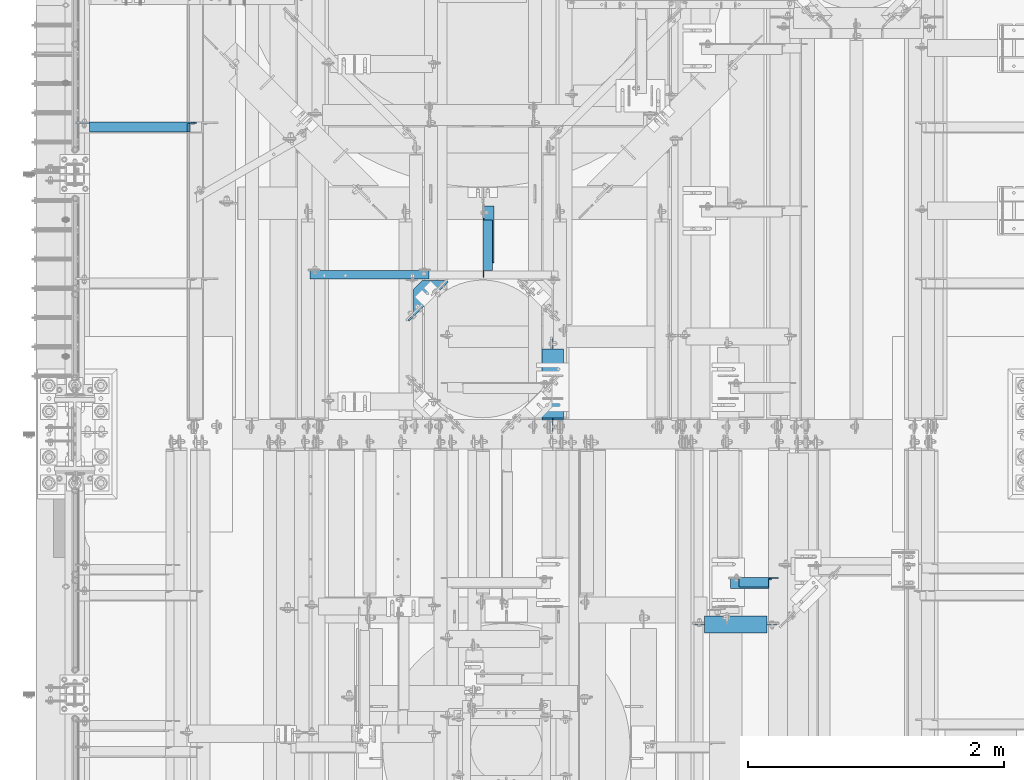
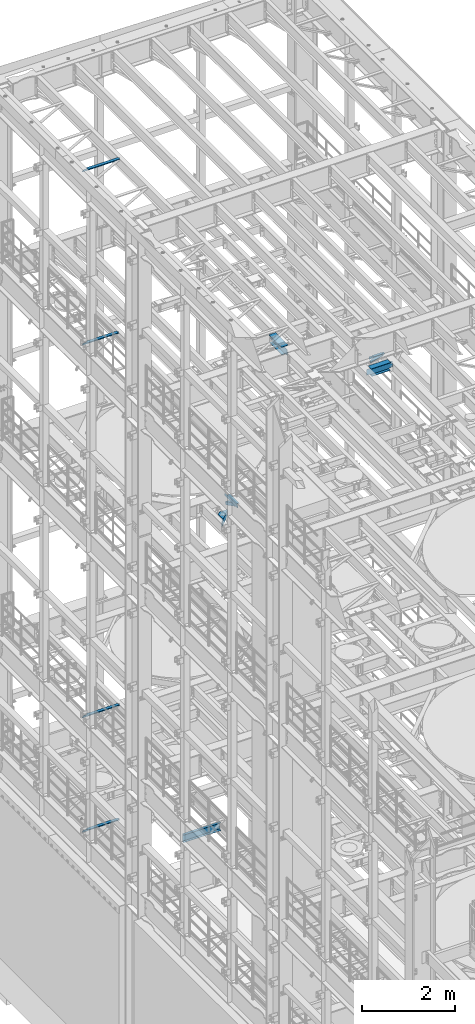
# One storey, part 1299 of 1876: 11 beams, 1 member, 12 elements without a shape of their own.
"""IFC2X3 building model written with IfcOpenShell, lengths in millimetres."""

from ifc_helpers import new_model, si_unit, frame, origin_with_axes, place, context, subcontext, project, spatial, faceted_brep, material, type_object, element, aggregate, save


model = new_model("IFC2X3")

# Units and contexts
model_context = context("Model", 3, precision=1e-05, world=origin_with_axes())
body_context = subcontext(model_context, "Body", "Model", "MODEL_VIEW")
ifc_project = project(units=[si_unit("LENGTHUNIT", "METRE", prefix="MILLI"), si_unit("AREAUNIT", "SQUARE_METRE"), si_unit("VOLUMEUNIT", "CUBIC_METRE"), si_unit("MASSUNIT", "GRAM", prefix="KILO"), si_unit("TIMEUNIT", "SECOND"), si_unit("PLANEANGLEUNIT", "RADIAN"), si_unit("SOLIDANGLEUNIT", "STERADIAN"), si_unit("THERMODYNAMICTEMPERATUREUNIT", "DEGREE_CELSIUS"), si_unit("LUMINOUSINTENSITYUNIT", "LUMEN")], contexts=[model_context])

# Site, building, storey
site_placement = place(None, origin_with_axes())
site = spatial("IfcSite", under=ifc_project, at=site_placement, CompositionType="ELEMENT")
building_placement = place(site_placement, origin_with_axes())
building = spatial("IfcBuilding", under=site, at=building_placement, Name="Undefined", CompositionType="ELEMENT")
storey_placement = place(building_placement, origin_with_axes())
storey = spatial("IfcBuildingStorey", under=building, at=storey_placement, Name="Undefined", CompositionType="ELEMENT", Elevation=0.0)

# Assembly, beam
assembly_1_placement = place(storey_placement, origin_with_axes())
assembly_1 = element("IfcElementAssembly", 1, at=assembly_1_placement, inside=storey, Name="BEAM", AssemblyPlace="NOTDEFINED", PredefinedType="RIGID_FRAME")
ifc_material_1 = material(Name="STEEL/A992")
beam_type_1 = type_object("IfcBeamType", Name="W8X24", PredefinedType="NOTDEFINED")
beam_1_placement = place(assembly_1_placement, frame((3733.80030602581, 7620.00328419141, 17883.1875), z_axis=(0.0, 0.0, 1.0), x_axis=(0.0, 1.0, 0.0)))
beam_1 = element("IfcBeam", 2, at=beam_1_placement, type_object=beam_type_1, material=ifc_material_1, Name="BEAM", ObjectType="W8X24", context=body_context, shape_type="Brep", body=[
    faceted_brep([(19.8404658085947, -3.17500000000018, -80.9624999999978), (19.8404658085947, 3.17500000000018, -80.9624999999978), (99.2154659993294, 3.17500000000018, -80.9624999999978), (99.2154659993294, -3.17500000000018, -80.9624999999978), (104.075545517375, 3.17500000000018, -81.9292299225854), (104.075545517375, -3.17500000000018, -81.9292299225854), (108.195721985529, 3.17500000000018, -84.6822438230629), (108.195721985529, -3.17500000000018, -84.6822438230629), (110.948735886007, 3.17500000000018, -88.8024202912165), (110.948735886007, -3.17500000000018, -88.8024202912165), (111.915465808594, -82.5500000000002, -93.662499809263), (111.915465808594, 82.5500000000002, -93.662499809263), (111.915465808594, 82.5500000000002, -100.012500000001), (111.915465808594, -82.5500000000002, -100.012500000001), (111.283919080104, -82.5500000000002, -90.4874999999993), (111.283919080104, -3.17500000000018, -90.4874999999993), (111.283919080104, 3.17500000000018, -90.4874999999993), (111.283919080104, 82.5500000000002, -90.4874999999993), (666.746715808596, -82.5500000000002, 100.012500000001), (666.746715808596, 82.5500000000002, 100.012500000001), (127.790465808594, 82.5500000000002, 100.012500000001), (127.790465808594, -82.5500000000002, 100.012500000001), (667.378262537088, -82.5500000000002, 90.4874999999993), (666.746715808596, -82.5500000000002, 93.6624998092666), (127.790465808594, -82.5500000000002, 90.4874999999993), (666.746715808596, 82.5500000000002, 93.6624998092666), (667.378262537088, 82.5500000000002, 90.4874999999993), (127.790465808594, 82.5500000000002, 90.4874999999993), (667.378262537088, 3.17500000000018, 90.4874999999993), (127.790465808594, 3.17500000000018, 90.4874999999993), (115.090465999329, -3.17500000000018, 61.9125000000058), (115.090465999329, 3.17500000000018, 61.9125000000058), (19.8404658085947, 3.17500000000018, 61.9125000000058), (19.8404658085947, -3.17500000000018, 61.9125000000058), (119.950545517375, -3.17500000000018, 62.8792299225934), (119.950545517375, 3.17500000000018, 62.8792299225934), (124.070721985529, -3.17500000000018, 65.6322438230709), (124.070721985529, 3.17500000000018, 65.6322438230709), (126.823735886007, -3.17500000000018, 69.7524202912246), (126.823735886007, 3.17500000000018, 69.7524202912246), (127.790465808594, -3.17500000000018, 74.612499809271), (127.790465808594, 3.17500000000018, 74.612499809271), (127.790465808594, -3.17500000000018, 90.4874999999993), (667.378262537088, -3.17500000000018, 90.4874999999993), (667.713445731184, -3.17500000000018, 88.8024202912202), (667.713445731184, 3.17500000000018, 88.8024202912202), (670.466459631662, -3.17500000000018, 84.6822438230665), (670.466459631662, 3.17500000000018, 84.6822438230665), (674.586636099815, -3.17500000000018, 81.929229922589), (674.586636099815, 3.17500000000018, 81.929229922589), (679.446715617862, -3.17500000000018, 80.9625000000015), (679.446715617862, 3.17500000000018, 80.9625000000015), (746.121715808595, -3.17500000000018, 80.9625000000015), (746.121715808595, 3.17500000000018, 80.9625000000015), (746.121715808595, -3.17500000000018, -74.6124999999993), (746.121715808595, 3.17500000000018, -74.6124999999993), (666.746715617861, -3.17500000000018, -74.6124999999993), (666.746715617861, 3.17500000000018, -74.6124999999993), (661.886636099814, -3.17500000000018, -75.5792299225868), (661.886636099814, 3.17500000000018, -75.5792299225868), (657.766459631661, -3.17500000000018, -78.3322438230643), (657.766459631661, 3.17500000000018, -78.3322438230643), (655.013445731183, -3.17500000000018, -82.452420291218), (655.013445731183, 3.17500000000018, -82.452420291218), (654.046715808596, -3.17500000000018, -87.3124998092644), (654.046715808596, 3.17500000000018, -87.3124998092644), (654.046715808596, -3.17500000000018, -90.4874999999993), (654.046715808596, -82.5500000000002, -90.4874999999993), (654.046715808596, -82.5500000000002, -100.012500000001), (654.046715808596, 82.5500000000002, -100.012500000001), (654.046715808596, 82.5500000000002, -90.4874999999993), (654.046715808596, 3.17500000000018, -90.4874999999993)], [[[0, 1, 2, 3]], [[3, 2, 4, 5]], [[5, 4, 6, 7]], [[7, 6, 8, 9]], [[10, 11, 12, 13]], [[14, 15, 9, 8, 16, 17, 11, 10]], [[18, 19, 20, 21]], [[22, 23, 18, 21, 24]], [[18, 23, 25, 19]], [[19, 25, 26, 27, 20]], [[26, 28, 29, 27]], [[30, 31, 32, 33]], [[34, 35, 31, 30]], [[36, 37, 35, 34]], [[38, 39, 37, 36]], [[40, 41, 39, 38]], [[21, 20, 27, 29, 41, 40, 42, 24]], [[43, 22, 24, 42]], [[44, 45, 28, 26, 25, 23, 22, 43]], [[46, 47, 45, 44]], [[48, 49, 47, 46]], [[50, 51, 49, 48]], [[52, 53, 51, 50]], [[53, 52, 54, 55]], [[54, 56, 57, 55]], [[58, 59, 57, 56]], [[60, 61, 59, 58]], [[62, 63, 61, 60]], [[64, 65, 63, 62]], [[66, 67, 68, 69, 70, 71, 65, 64]], [[69, 68, 13, 12]], [[70, 69, 12, 11, 17]], [[71, 70, 17, 16]], [[6, 4, 2, 1, 32, 31, 35, 37, 39, 41, 29, 28, 45, 47, 49, 51, 53, 55, 57, 59, 61, 63, 65, 71, 16, 8]], [[33, 32, 1, 0]], [[66, 64, 62, 60, 58, 56, 54, 52, 50, 48, 46, 44, 43, 42, 40, 38, 36, 34, 30, 33, 0, 3, 5, 7, 9, 15]], [[67, 66, 15, 14]], [[68, 67, 14, 10, 13]]]),
])
aggregate(assembly_1, [beam_1])

# Assembly, member
assembly_2_placement = place(storey_placement, origin_with_axes())
assembly_2 = element("IfcElementAssembly", 3, at=assembly_2_placement, inside=storey, AssemblyPlace="NOTDEFINED", PredefinedType="RIGID_FRAME")
ifc_material_2 = material(Name="STEEL/A36")
member_type = type_object("IfcMemberType", Name="L3X3X3/8", PredefinedType="NOTDEFINED")
member_placement = place(assembly_2_placement, frame((3235.325, 8832.85, 13309.6), z_axis=(1.0, 0.0, 0.0), x_axis=(0.0, 0.892499599264646, -0.451048185133747)))
member = element("IfcMember", 4, at=member_placement, type_object=member_type, material=ifc_material_2, ObjectType="L3X3X3/8", context=body_context, shape_type="Brep", body=[
    faceted_brep([(124.663476287255, 38.0999999999112, -38.0999999999999), (124.663476287255, 38.0999999999112, 38.0999999999999), (621.970939374316, 38.0999999996584, 38.0999999999999), (621.970939374316, 38.0999999996584, -38.0999999999999), (124.663476287255, 28.5749999999189, 38.0999999999999), (621.970939374316, 28.5749999996642, 38.0999999999999), (124.663476287255, 28.5749999999189, -28.5749999999998), (621.970939374316, 28.5749999996642, -28.5749999999998), (124.663476287255, -38.1000000000367, -28.5749999999998), (621.970939374316, -38.100000000295, -28.5749999999998), (124.663476287255, -38.1000000000367, -38.0999999999999), (621.970939374316, -38.100000000295, -38.0999999999999)], [[[0, 1, 2, 3]], [[1, 4, 5, 2]], [[4, 6, 7, 5]], [[6, 8, 9, 7]], [[8, 10, 11, 9]], [[10, 0, 3, 11]], [[5, 7, 9, 11, 3, 2]], [[10, 8, 6, 4, 1, 0]]]),
])
aggregate(assembly_2, [member])

# Assembly, beam
assembly_3_placement = place(storey_placement, origin_with_axes())
assembly_3 = element("IfcElementAssembly", 5, at=assembly_3_placement, inside=storey, AssemblyPlace="NOTDEFINED", PredefinedType="RIGID_FRAME")
beam_type_2 = type_object("IfcBeamType", Name="L3X3X3/8", PredefinedType="NOTDEFINED")
beam_2_placement = place(assembly_3_placement, frame((5115.67188394865, 6454.18029605649, 17835.3860674882), z_axis=(0.0, -1.0, 0.0), x_axis=(0.962964108055377, 9.90000136870752e-08, 0.269629610015487)))
beam_2 = element("IfcBeam", 6, at=beam_2_placement, type_object=beam_type_2, material=ifc_material_2, ObjectType="L3X3X3/8", context=body_context, shape_type="Brep", body=[
    faceted_brep([(16.4868910748646, 38.0999999999713, -38.1000000000222), (16.4868910889727, 38.0999999998912, 38.0999999999785), (329.711563972696, 38.0999999996693, 38.0999999998785), (329.711563958586, 38.0999999997493, -38.1000000001222), (16.4868910889854, 28.5749999999061, 38.0999999999822), (329.711563972709, 28.5749999996842, 38.099999999883), (16.4868910766399, 28.5749999999753, -28.5750000000189), (329.711563960363, 28.5749999997533, -28.5750000001181), (16.4868910767309, -38.099999999924, -28.5749999999898), (329.711563960454, -38.1000000001422, -28.5750000000899), (16.4868910749683, -38.0999999999131, -38.0999999999894), (329.71156395869, -38.100000000135, -38.1000000000895)], [[[0, 1, 2, 3]], [[1, 4, 5, 2]], [[4, 6, 7, 5]], [[6, 8, 9, 7]], [[8, 10, 11, 9]], [[10, 0, 3, 11]], [[5, 7, 9, 11, 3, 2]], [[10, 8, 6, 4, 1, 0]]]),
])
aggregate(assembly_3, [beam_2])

assembly_4_placement = place(storey_placement, origin_with_axes())
assembly_4 = element("IfcElementAssembly", 7, at=assembly_4_placement, inside=storey, Name="ANGLE", AssemblyPlace="NOTDEFINED", PredefinedType="RIGID_FRAME")
beam_3_placement = place(assembly_4_placement, frame((5105.39898445268, 6463.7052979603, 17945.1), z_axis=(0.0, -1.0, 0.0), x_axis=(1.0, 0.0, 0.0)))
beam_3 = element("IfcBeam", 8, at=beam_3_placement, type_object=beam_type_2, material=ifc_material_2, Name="ANGLE", ObjectType="L3X3X3/8", context=body_context, shape_type="Brep", body=[
    faceted_brep([(84.1370686928021, 28.5750001907327, 38.100000000024), (84.1374011325761, 38.0999999999985, 38.0999999999776), (84.137408980816, 38.0999999999985, -38.1000000000231), (84.1370595487806, 28.5750001907327, -38.0999999999776), (84.1370606917826, 28.5750000000007, -28.5749999999771), (15.8750613722059, 28.5750001907327, -38.0999999999958), (15.8750625152097, 28.5750000000007, -28.5749999999953), (3.17506156294075, 15.8750003814675, -38.0999999999995), (3.17506270594458, 15.8750003814675, -28.5749999999989), (3.17506156294075, 3.17500152587672, -38.0999999999995), (3.17506270594458, 3.17500152587672, -28.5749999999989), (3.17506108428279, -38.0999999999985, -38.0999999999995), (3.17506206535836, -38.0999999999985, -28.5749999999989), (393.701020032223, 7.93700303403966, -28.575000000109), (374.651020795162, 26.9870022711002, -28.5750000001026), (312.739018490534, 26.9870022711002, -28.5750000000862), (312.738962921262, 28.5750000000007, -28.5750000000862), (393.701018506342, -38.0999999999985, -28.575000000109), (393.701020032223, 1.58700265256994, -28.575000000109), (312.738956053971, 28.5750004633555, 38.0999999999149), (312.738622742861, 38.0999999999985, 38.0999999999149), (312.738630591175, 38.0999999999985, -38.1000000000868), (312.73901947161, 26.9870012519241, -38.1000000000868), (374.651021776237, 26.9870012519241, -38.1000000001031), (393.701021013298, 7.9370020148599, -38.1000000001086), (393.701021013298, 1.58700163339017, -38.1000000001086), (393.701019487417, -38.0999999999985, -38.1000000001086)], [[[0, 1, 2, 3, 4]], [[4, 3, 5, 6]], [[6, 5, 7, 8]], [[8, 7, 9, 10]], [[9, 11, 12, 10]], [[13, 14, 15, 16, 4, 6, 8, 10, 12, 17, 18]], [[0, 4, 16, 19]], [[1, 0, 19, 20]], [[2, 1, 20, 21]], [[19, 16, 15, 22, 21, 20]], [[14, 23, 22, 15]], [[13, 24, 23, 14]], [[18, 25, 24, 13]], [[11, 9, 7, 5, 3, 2, 21, 22, 23, 24, 25, 26]], [[12, 11, 26, 17]], [[25, 18, 17, 26]]]),
])
aggregate(assembly_4, [beam_3])

assembly_5_placement = place(storey_placement, origin_with_axes())
assembly_5 = element("IfcElementAssembly", 9, at=assembly_5_placement, inside=storey, Name="ANGLE", AssemblyPlace="NOTDEFINED", PredefinedType="RIGID_FRAME")
beam_4_placement = place(assembly_5_placement, frame((3225.8, 8832.85, 13271.5), z_axis=(1.0, 0.0, 0.0), x_axis=(0.0, 1.0, 0.0)))
beam_4 = element("IfcBeam", 10, at=beam_4_placement, type_object=beam_type_2, material=ifc_material_2, Name="ANGLE", ObjectType="L3X3X3/8", context=body_context, shape_type="Brep", body=[
    faceted_brep([(461.963000256203, 28.5750000000007, -28.5749999999998), (461.963001056292, 28.5750000000007, 38.0999999999999), (65.086999670908, 28.5750001907345, 38.0999999999999), (65.0869979373147, 28.5750000000007, -28.5749999999998), (461.963001056292, 38.1000000000004, 38.0999999999999), (65.086999670888, 38.1000000000004, 38.0999999999999), (31.7499961368012, 28.5750000000007, -28.5749999999998), (31.7499958891458, 28.5750001907345, -38.0999999999999), (12.6999966520852, 9.52500095367395, -38.0999999999999), (12.6999968997407, 9.52500095367395, -28.5749999999998), (65.0869976896593, 28.5750001907345, -38.0999999999999), (65.0869976896738, 38.1000000000004, -38.0999999999999), (461.963000141903, 38.1000000000004, -38.0999999999999), (461.963000256203, 19.0499996185299, -28.5749999999998), (461.963000141903, 19.0499996185299, -38.0999999999999), (559.593747097633, 19.0499996185299, -28.5749999999998), (559.593746983333, 19.0499996185299, -38.0999999999999), (584.993746716164, -6.35000000000036, -28.5749999999998), (584.993746601864, -6.35000000000036, -38.0999999999999), (584.993749999996, -38.1000000000004, -28.5749999999998), (584.993749999996, -38.1000000000004, -38.0999999999999), (12.6999999999989, -38.1000000000004, -28.5749999999998), (12.6999999999989, -38.1000000000004, -38.0999999999999), (12.6999966520852, 3.17500152587854, -38.0999999999999), (12.6999968997407, 3.17500152587854, -28.5749999999998)], [[[0, 1, 2, 3]], [[1, 4, 5, 2]], [[6, 7, 8, 9]], [[3, 10, 7, 6]], [[2, 5, 11, 10, 3]], [[4, 12, 11, 5]], [[1, 0, 13, 14, 12, 4]], [[15, 16, 14, 13]], [[16, 15, 17, 18]], [[18, 17, 19, 20]], [[20, 19, 21, 22]], [[8, 7, 10, 11, 12, 14, 16, 18, 20, 22, 23]], [[9, 8, 23, 24]], [[19, 17, 15, 13, 0, 3, 6, 9, 24, 21]], [[23, 22, 21, 24]]]),
])
aggregate(assembly_5, [beam_4])

assembly_6_placement = place(storey_placement, origin_with_axes())
assembly_6 = element("IfcElementAssembly", 11, at=assembly_6_placement, inside=storey, Name="ANGLE", AssemblyPlace="NOTDEFINED", PredefinedType="RIGID_FRAME")
beam_5_placement = place(assembly_6_placement, frame((4.51516825708356e-09, 10020.3, 22517.1), z_axis=(0.0, -1.0, 0.0), x_axis=(1.0, 0.0, 0.0)))
beam_5 = element("IfcBeam", 12, at=beam_5_placement, type_object=beam_type_2, material=ifc_material_2, Name="ANGLE", ObjectType="L3X3X3/8", context=body_context, shape_type="Brep", body=[
    faceted_brep([(115.886999817316, 28.5750000000007, 38.0999999999999), (115.886999817316, 38.0999999999985, 38.0999999999999), (115.886998826692, 38.0999999999985, -38.0999999999999), (115.88699882669, 12.699999237062, -38.0999999999999), (115.886998950515, 12.699999237062, -28.5749999999998), (115.88699895052, 28.5750000000007, -28.5749999999998), (38.8937432114558, 12.699999237062, -38.0999999999999), (38.8937433352807, 12.699999237062, -28.5749999999998), (7.14374321145577, -19.050000762938, -38.0999999999999), (7.14374333528067, -19.050000762938, -28.5749999999998), (7.1437499954859, -38.0999999999985, -38.0999999999999), (7.1437499954859, -38.0999999999985, -28.5749999999998), (949.325002419604, 15.8750003814712, -28.5749999999998), (936.625002610339, 28.5750000000007, -28.5749999999998), (900.113000619098, 28.5750000000007, -28.5749999999998), (949.324999995485, -38.0999999999985, -28.5749999999998), (949.325002419604, 3.17500152588036, -28.5749999999998), (900.11300241932, 28.5750000000007, 38.0999999999999), (900.1130024193, 38.0999999999985, 38.0999999999999), (900.113000361957, 38.0999999999985, -38.0999999999999), (900.113000361924, 28.5750001907363, -38.0999999999999), (936.625002353164, 28.5750001907363, -38.0999999999999), (949.325002162429, 15.8750003814712, -38.0999999999999), (949.325002162429, 3.17500152588036, -38.0999999999999), (949.324999995485, -38.0999999999985, -38.0999999999999)], [[[0, 1, 2, 3, 4, 5]], [[4, 3, 6, 7]], [[7, 6, 8, 9]], [[8, 10, 11, 9]], [[12, 13, 14, 5, 4, 7, 9, 11, 15, 16]], [[0, 5, 14, 17]], [[1, 0, 17, 18]], [[2, 1, 18, 19]], [[17, 14, 20, 19, 18]], [[13, 21, 20, 14]], [[12, 22, 21, 13]], [[16, 23, 22, 12]], [[10, 8, 6, 3, 2, 19, 20, 21, 22, 23, 24]], [[11, 10, 24, 15]], [[23, 16, 15, 24]]]),
])
aggregate(assembly_6, [beam_5])

assembly_7_placement = place(storey_placement, origin_with_axes())
assembly_7 = element("IfcElementAssembly", 13, at=assembly_7_placement, inside=storey, Name="ANGLE", AssemblyPlace="NOTDEFINED", PredefinedType="RIGID_FRAME")
beam_6_placement = place(assembly_7_placement, frame((2.91964701648869e-08, 10020.3, 17945.1), z_axis=(0.0, -1.0, 0.0), x_axis=(1.0, 0.0, 0.0)))
beam_6 = element("IfcBeam", 14, at=beam_6_placement, type_object=beam_type_2, material=ifc_material_2, Name="ANGLE", ObjectType="L3X3X3/8", context=body_context, shape_type="Brep", body=[
    faceted_brep([(115.886999817316, 28.5750000000007, 38.0999999999999), (115.886999817316, 38.0999999999985, 38.0999999999999), (115.886998826692, 38.0999999999985, -38.0999999999999), (115.88699882669, 12.699999237062, -38.0999999999999), (115.886998950515, 12.699999237062, -28.5749999999998), (115.88699895052, 28.5750000000007, -28.5749999999998), (38.8937432114558, 12.699999237062, -38.0999999999999), (38.8937433352807, 12.699999237062, -28.5749999999998), (7.14374321145577, -19.050000762938, -38.0999999999999), (7.14374333528067, -19.050000762938, -28.5749999999998), (7.1437499954859, -38.0999999999985, -38.0999999999999), (7.1437499954859, -38.0999999999985, -28.5749999999998), (923.925002394923, 15.8750003814748, -28.5750000000007), (911.225002585658, 28.5750000000007, -28.5750000000007), (874.713000594384, 28.5750000000007, -28.5750000000007), (923.924999986645, -38.0999999999985, -28.5750000000007), (923.925002394923, 3.175001525884, -28.5750000000007), (874.713002394605, 28.5750000000007, 38.1000000000004), (874.713002394611, 38.0999999999985, 38.1000000000004), (874.713000337267, 38.0999999999985, -38.1000000000004), (874.71300033721, 28.57500019074, -38.1000000000004), (911.225002328483, 28.57500019074, -38.1000000000004), (923.925002137748, 15.8750003814748, -38.1000000000004), (923.925002137748, 3.175001525884, -38.1000000000004), (923.924999986645, -38.0999999999985, -38.1000000000004)], [[[0, 1, 2, 3, 4, 5]], [[4, 3, 6, 7]], [[7, 6, 8, 9]], [[8, 10, 11, 9]], [[12, 13, 14, 5, 4, 7, 9, 11, 15, 16]], [[0, 5, 14, 17]], [[1, 0, 17, 18]], [[2, 1, 18, 19]], [[17, 14, 20, 19, 18]], [[13, 21, 20, 14]], [[12, 22, 21, 13]], [[16, 23, 22, 12]], [[10, 8, 6, 3, 2, 19, 20, 21, 22, 23, 24]], [[11, 10, 24, 15]], [[23, 16, 15, 24]]]),
])
aggregate(assembly_7, [beam_6])

assembly_8_placement = place(storey_placement, origin_with_axes())
assembly_8 = element("IfcElementAssembly", 15, at=assembly_8_placement, inside=storey, Name="ANGLE", AssemblyPlace="NOTDEFINED", PredefinedType="RIGID_FRAME")
beam_7_placement = place(assembly_8_placement, frame((4.54521503245139e-09, 10020.3, 8115.3), z_axis=(0.0, -1.0, 0.0), x_axis=(1.0, 0.0, 0.0)))
beam_7 = element("IfcBeam", 16, at=beam_7_placement, type_object=beam_type_2, material=ifc_material_2, Name="ANGLE", ObjectType="L3X3X3/8", context=body_context, shape_type="Brep", body=[
    faceted_brep([(115.886999817316, 28.5750000000007, 38.0999999999999), (115.886999817316, 38.0999999999985, 38.0999999999999), (115.886998826692, 38.0999999999985, -38.0999999999999), (115.88699882669, 12.699999237062, -38.0999999999999), (115.886998950515, 12.699999237062, -28.5749999999998), (115.88699895052, 28.5750000000007, -28.5749999999998), (38.8937432114558, 12.699999237062, -38.0999999999999), (38.8937433352807, 12.699999237062, -28.5749999999998), (7.14374321145577, -19.050000762938, -38.0999999999999), (7.14374333528067, -19.050000762938, -28.5749999999998), (7.1437499954859, -38.0999999999985, -38.0999999999999), (7.1437499954859, -38.0999999999985, -28.5749999999998), (942.975002419575, 15.8750003814703, -28.5750000000007), (930.27500261031, 28.5749999999998, -28.5750000000007), (893.763000619072, 28.5749999999998, -28.5750000000007), (942.974999995456, -38.1000000000004, -28.5750000000007), (942.975002419575, 3.17500152587945, -28.5750000000007), (893.763002419293, 28.5749999999998, 38.1000000000004), (893.763002419272, 38.1000000000004, 38.1000000000004), (893.763000361928, 38.1000000000004, -38.1000000000004), (893.763000361898, 28.5750001907354, -38.1000000000004), (930.275002353135, 28.5750001907354, -38.1000000000004), (942.9750021624, 15.8750003814703, -38.1000000000004), (942.9750021624, 3.17500152587945, -38.1000000000004), (942.974999995456, -38.1000000000004, -38.1000000000004)], [[[0, 1, 2, 3, 4, 5]], [[4, 3, 6, 7]], [[7, 6, 8, 9]], [[8, 10, 11, 9]], [[12, 13, 14, 5, 4, 7, 9, 11, 15, 16]], [[0, 5, 14, 17]], [[1, 0, 17, 18]], [[2, 1, 18, 19]], [[17, 14, 20, 19, 18]], [[13, 21, 20, 14]], [[12, 22, 21, 13]], [[16, 23, 22, 12]], [[10, 8, 6, 3, 2, 19, 20, 21, 22, 23, 24]], [[11, 10, 24, 15]], [[23, 16, 15, 24]]]),
])
aggregate(assembly_8, [beam_7])

assembly_9_placement = place(storey_placement, origin_with_axes())
assembly_9 = element("IfcElementAssembly", 17, at=assembly_9_placement, inside=storey, Name="ANGLE", AssemblyPlace="NOTDEFINED", PredefinedType="RIGID_FRAME")
beam_8_placement = place(assembly_9_placement, frame((0.0, 10020.3, 5092.7), z_axis=(0.0, -1.0, 0.0), x_axis=(1.0, 0.0, 0.0)))
beam_8 = element("IfcBeam", 18, at=beam_8_placement, type_object=beam_type_2, material=ifc_material_2, Name="ANGLE", ObjectType="L3X3X3/8", context=body_context, shape_type="Brep", body=[
    faceted_brep([(115.886999817316, 28.5750000000007, 38.0999999999999), (115.886999817316, 38.0999999999985, 38.0999999999999), (115.886998826692, 38.0999999999985, -38.0999999999999), (115.88699882669, 12.699999237062, -38.0999999999999), (115.886998950515, 12.699999237062, -28.5749999999998), (115.88699895052, 28.5750000000007, -28.5749999999998), (38.8937432114558, 12.699999237062, -38.0999999999999), (38.8937433352807, 12.699999237062, -28.5749999999998), (7.14374321145577, -19.050000762938, -38.0999999999999), (7.14374333528067, -19.050000762938, -28.5749999999998), (7.1437499954859, -38.0999999999985, -38.0999999999999), (7.1437499954859, -38.0999999999985, -28.5749999999998), (930.275002424124, 15.8750003814703, -28.5750000000007), (917.575002614859, 28.5749999999998, -28.5750000000007), (881.063000623622, 28.5749999999998, -28.5750000000007), (930.274999999999, -38.1000000000004, -28.5750000000007), (930.275002424124, 3.17500152587945, -28.5750000000007), (881.063002423843, 28.5749999999998, 38.1000000000004), (881.063002423821, 38.1000000000004, 38.1000000000004), (881.063000366478, 38.1000000000004, -38.1000000000004), (881.063000366447, 28.5750001907354, -38.1000000000004), (917.575002357685, 28.5750001907354, -38.1000000000004), (930.27500216695, 15.8750003814703, -38.1000000000004), (930.27500216695, 3.17500152587945, -38.1000000000004), (930.274999999999, -38.1000000000004, -38.1000000000004)], [[[0, 1, 2, 3, 4, 5]], [[4, 3, 6, 7]], [[7, 6, 8, 9]], [[8, 10, 11, 9]], [[12, 13, 14, 5, 4, 7, 9, 11, 15, 16]], [[0, 5, 14, 17]], [[1, 0, 17, 18]], [[2, 1, 18, 19]], [[17, 14, 20, 19, 18]], [[13, 21, 20, 14]], [[12, 22, 21, 13]], [[16, 23, 22, 12]], [[10, 8, 6, 3, 2, 19, 20, 21, 22, 23, 24]], [[11, 10, 24, 15]], [[23, 16, 15, 24]]]),
])
aggregate(assembly_9, [beam_8])

assembly_10_placement = place(storey_placement, origin_with_axes())
assembly_10 = element("IfcElementAssembly", 19, at=assembly_10_placement, inside=storey, Name="BEAM", AssemblyPlace="NOTDEFINED", PredefinedType="RIGID_FRAME")
beam_type_3 = type_object("IfcBeamType", Name="W8X18", PredefinedType="NOTDEFINED")
beam_9_placement = place(assembly_10_placement, frame((4826.0, 6133.50589599609, 17880.0125), z_axis=(0.0, 0.0, 1.0), x_axis=(1.0, 0.0, 0.0)))
beam_9 = element("IfcBeam", 20, at=beam_9_placement, type_object=beam_type_3, material=ifc_material_1, Name="BEAM", ObjectType="W8X18", context=body_context, shape_type="Brep", body=[
    faceted_brep([(568.325000000003, -3.17500000000018, -95.25), (568.325000000003, -66.6750000000002, -95.25), (568.325000000003, -66.6750000000002, -103.1875), (568.325000000003, 66.6750000000002, -103.1875), (568.325000000003, 66.6750000000002, -95.25), (568.325000000003, 3.17500000000018, -95.25), (568.325000000003, 3.17500000000018, -90.4874998092673), (568.325000000003, -3.17500000000018, -90.4874998092673), (569.29172992259, 3.17500000000018, -85.6274202912209), (569.29172992259, -3.17500000000018, -85.6274202912209), (572.044743823069, 3.17500000000018, -81.5072438230673), (572.044743823069, -3.17500000000018, -81.5072438230673), (576.164920291222, 3.17500000000018, -78.7542299225897), (576.164920291222, -3.17500000000018, -78.7542299225897), (581.024999809268, 3.17500000000018, -77.7875000000022), (581.024999809268, -3.17500000000018, -77.7875000000022), (660.400000000001, -3.17500000000018, -77.7875000000022), (660.400000000001, 3.17500000000018, -77.7875000000022), (95.25, 3.17500000000018, 95.25), (95.25, 66.6750000000002, 95.25), (581.025000000002, 66.6750000000002, 95.25), (581.025000000002, 3.17500000000018, 95.25), (107.950000000001, -3.17500000000018, -90.48749980926), (107.950000000001, 3.17500000000018, -90.48749980926), (107.950000000001, 3.17500000000018, -95.25), (107.950000000001, 66.6750000000002, -95.25), (107.950000000001, 66.6750000000002, -103.1875), (107.950000000001, -66.6750000000002, -103.1875), (107.950000000001, -66.6750000000002, -95.25), (107.950000000001, -3.17500000000018, -95.25), (106.983270077413, -3.17500000000018, -85.6274202912136), (106.983270077413, 3.17500000000018, -85.6274202912136), (104.230256176935, -3.17500000000018, -81.50724382306), (104.230256176935, 3.17500000000018, -81.50724382306), (100.110079708781, -3.17500000000018, -78.7542299225825), (100.110079708781, 3.17500000000018, -78.7542299225825), (95.2500001907356, -3.17500000000018, -77.7874999999949), (95.2500001907356, 3.17500000000018, -77.7874999999949), (15.875, -3.17500000000018, -77.7874999999949), (15.875, 3.17500000000018, -77.7874999999949), (15.875, -3.17500000000018, 77.7874999999949), (15.875, 3.17500000000018, 77.7874999999949), (82.5500001907349, -3.17500000000018, 77.7874999999949), (82.5500001907349, 3.17500000000018, 77.7874999999949), (87.4100797087804, -3.17500000000018, 78.7542299225825), (87.4100797087804, 3.17500000000018, 78.7542299225825), (91.530256176934, -3.17500000000018, 81.50724382306), (91.530256176934, 3.17500000000018, 81.50724382306), (94.2832700774125, -3.17500000000018, 85.6274202912136), (94.2832700774125, 3.17500000000018, 85.6274202912136), (95.25, -3.17500000000018, 90.48749980926), (95.25, 3.17500000000018, 90.48749980926), (95.25, -66.6750000000002, 103.1875), (95.25, 66.6750000000002, 103.1875), (95.25, -3.17500000000018, 95.25), (95.25, -66.6750000000002, 95.25), (581.025000000002, -3.17500000000018, 95.25), (581.025000000002, -66.6750000000002, 95.25), (581.025000000002, -66.6750000000002, 103.1875), (581.025000000002, 66.6750000000002, 103.1875), (581.025000000002, -3.17500000000018, 90.48749980926), (581.025000000002, 3.17500000000018, 90.48749980926), (581.99172992259, -3.17500000000018, 85.6274202912136), (581.99172992259, 3.17500000000018, 85.6274202912136), (584.744743823068, -3.17500000000018, 81.50724382306), (584.744743823068, 3.17500000000018, 81.50724382306), (588.864920291222, -3.17500000000018, 78.7542299225825), (588.864920291222, 3.17500000000018, 78.7542299225825), (593.724999809268, -3.17500000000018, 77.7874999999949), (593.724999809268, 3.17500000000018, 77.7874999999949), (660.400000000001, -3.17500000000018, 77.7874999999949), (660.400000000001, 3.17500000000018, 77.7874999999949)], [[[0, 1, 2, 3, 4, 5, 6, 7]], [[7, 6, 8, 9]], [[9, 8, 10, 11]], [[11, 10, 12, 13]], [[13, 12, 14, 15]], [[16, 15, 14, 17]], [[18, 19, 20, 21]], [[22, 23, 24, 25, 26, 27, 28, 29]], [[30, 31, 23, 22]], [[32, 33, 31, 30]], [[34, 35, 33, 32]], [[36, 37, 35, 34]], [[38, 39, 37, 36]], [[40, 41, 39, 38]], [[42, 43, 41, 40]], [[44, 45, 43, 42]], [[46, 47, 45, 44]], [[48, 49, 47, 46]], [[50, 51, 49, 48]], [[52, 53, 19, 18, 51, 50, 54, 55]], [[55, 54, 56, 57]], [[52, 55, 57, 58]], [[53, 52, 58, 59]], [[19, 53, 59, 20]], [[58, 57, 56, 60, 61, 21, 20, 59]], [[62, 63, 61, 60]], [[64, 65, 63, 62]], [[66, 67, 65, 64]], [[68, 69, 67, 66]], [[70, 71, 69, 68]], [[71, 70, 16, 17]], [[12, 10, 8, 6, 5, 24, 23, 31, 33, 35, 37, 39, 41, 43, 45, 47, 49, 51, 18, 21, 61, 63, 65, 67, 69, 71, 17, 14]], [[25, 24, 5, 4]], [[26, 25, 4, 3]], [[27, 26, 3, 2]], [[28, 27, 2, 1]], [[29, 28, 1, 0]], [[70, 68, 66, 64, 62, 60, 56, 54, 50, 48, 46, 44, 42, 40, 38, 36, 34, 32, 30, 22, 29, 0, 7, 9, 11, 13, 15, 16]]]),
])
aggregate(assembly_10, [beam_9])

assembly_11_placement = place(storey_placement, origin_with_axes())
assembly_11 = element("IfcElementAssembly", 21, at=assembly_11_placement, inside=storey, Name="BEAM", AssemblyPlace="NOTDEFINED", PredefinedType="RIGID_FRAME")
beam_type_4 = type_object("IfcBeamType", Name="C8X18.75", PredefinedType="NOTDEFINED")
beam_10_placement = place(assembly_11_placement, frame((1825.625, 8866.18854370117, 4981.575), z_axis=(0.0, 0.0, 1.0), x_axis=(1.0, 0.0, 0.0)))
beam_10 = element("IfcBeam", 22, at=beam_10_placement, type_object=beam_type_4, material=ifc_material_2, Name="BEAM", ObjectType="C8X18.75", context=body_context, shape_type="Brep", body=[
    faceted_brep([(12.6999999999991, 31.75, -101.6), (12.6999999999991, 31.75, 101.6), (939.800000000001, 31.75, 101.6), (939.800000000001, 31.75, -101.6), (12.6999999999991, -31.75, 101.6), (939.800000000001, -31.75, 101.6), (12.6999999999991, -31.75, 97.3645500000002), (939.800000000001, -31.75, 97.3645500000002), (12.6999999999991, 19.0499999999993, 88.9012700000003), (939.800000000001, 19.0499999999993, 88.9012700000003), (12.6999999999991, 19.0499999999993, -88.9012700000003), (939.800000000001, 19.0499999999993, -88.9012700000003), (12.6999999999991, -31.75, -97.3645500000002), (939.800000000001, -31.75, -97.3645500000002), (12.6999999999991, -31.75, -101.6), (939.800000000001, -31.75, -101.6)], [[[0, 1, 2, 3]], [[1, 4, 5, 2]], [[4, 6, 7, 5]], [[6, 8, 9, 7]], [[8, 10, 11, 9]], [[10, 12, 13, 11]], [[12, 14, 15, 13]], [[14, 0, 3, 15]], [[5, 7, 9, 11, 13, 15, 3, 2]], [[14, 12, 10, 8, 6, 4, 1, 0]]]),
])
aggregate(assembly_11, [beam_10])

assembly_12_placement = place(storey_placement, origin_with_axes())
assembly_12 = element("IfcElementAssembly", 23, at=assembly_12_placement, inside=storey, Name="BEAM", AssemblyPlace="NOTDEFINED", PredefinedType="RIGID_FRAME")
beam_type_5 = type_object("IfcBeamType", Name="L6X6X5/8", PredefinedType="NOTDEFINED")
beam_11_placement = place(assembly_12_placement, frame((2530.56846327334, 8528.82038418136, 13233.4), z_axis=(0.0, 0.0, -1.0), x_axis=(0.707106781186548, 0.707106781186547, 0.0)))
beam_11 = element("IfcBeam", 24, at=beam_11_placement, type_object=beam_type_5, material=ifc_material_2, Name="BEAM", ObjectType="L6X6X5/8", context=body_context, shape_type="Brep", body=[
    faceted_brep([(38.32564030304, 60.3250000000098, 76.2000000000007), (38.3256403030437, 60.3250000000053, -47.625), (38.3256403030437, 76.2000000000135, 76.2000000000007), (38.3256403030437, 76.2000000000135, -47.625), (71.8420492387722, 76.2000000000126, -47.625), (87.717049238775, 60.3250000000098, -47.625), (78.7152396074061, 76.2000000000135, -48.5917299225875), (94.5902396074089, 60.3250000000098, -48.5917299225875), (84.5420490480419, 76.2000000000126, -51.3447438230651), (100.417049048045, 60.3250000000098, -51.3447438230651), (88.4353986435008, 76.2000000000126, -55.4649202912187), (104.310398643504, 60.3250000000098, -55.4649202912187), (472.327293811817, 60.3250000000107, -60.3250000000007), (335.802293811794, -76.2000000000126, -60.3250000000007), (335.802293811794, -76.2000000000126, -76.2000000000007), (472.327293811813, 60.3250000000062, -76.2000000000007), (472.327293811817, 60.3250000000107, 76.2000000000007), (105.677561210605, 60.3250000000007, -60.3250000000098), (242.202561211203, -76.2000000000135, -60.3249998092651), (242.202561211203, -76.2000000000135, -76.2000000000007), (89.8025612106017, 76.2000000000007, -76.2000000000135), (472.327293811812, 76.2000000000126, -76.2000000000007), (89.802561211176, 76.2000000000126, -60.3249998092651), (472.327293811812, 76.2000000000135, 76.2000000000007)], [[[0, 1, 1]], [[0, 2, 3, 1]], [[1, 1, 3, 4, 5]], [[5, 4, 6, 7]], [[7, 6, 8, 9]], [[9, 8, 10, 11]], [[12, 13, 14, 15, 16]], [[13, 12, 17, 18]], [[14, 13, 18, 19]], [[14, 19, 20, 21, 15]], [[18, 17, 22, 20, 19]], [[11, 10, 22, 17]], [[12, 16, 0, 1, 5, 7, 9, 11, 17]], [[2, 0, 16, 23]], [[20, 22, 10, 8, 6, 4, 3, 2, 23, 21]], [[16, 15, 21, 23]]]),
])
aggregate(assembly_12, [beam_11])

save(model, "model.ifc")
